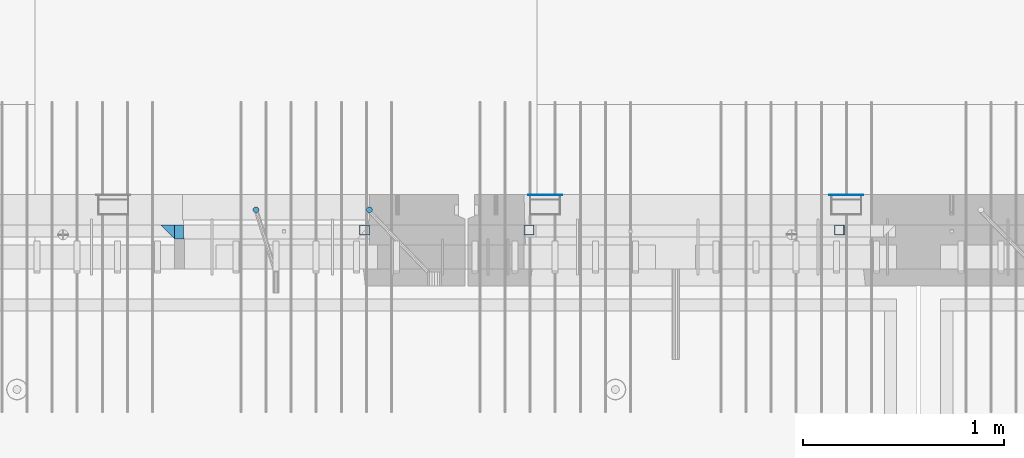
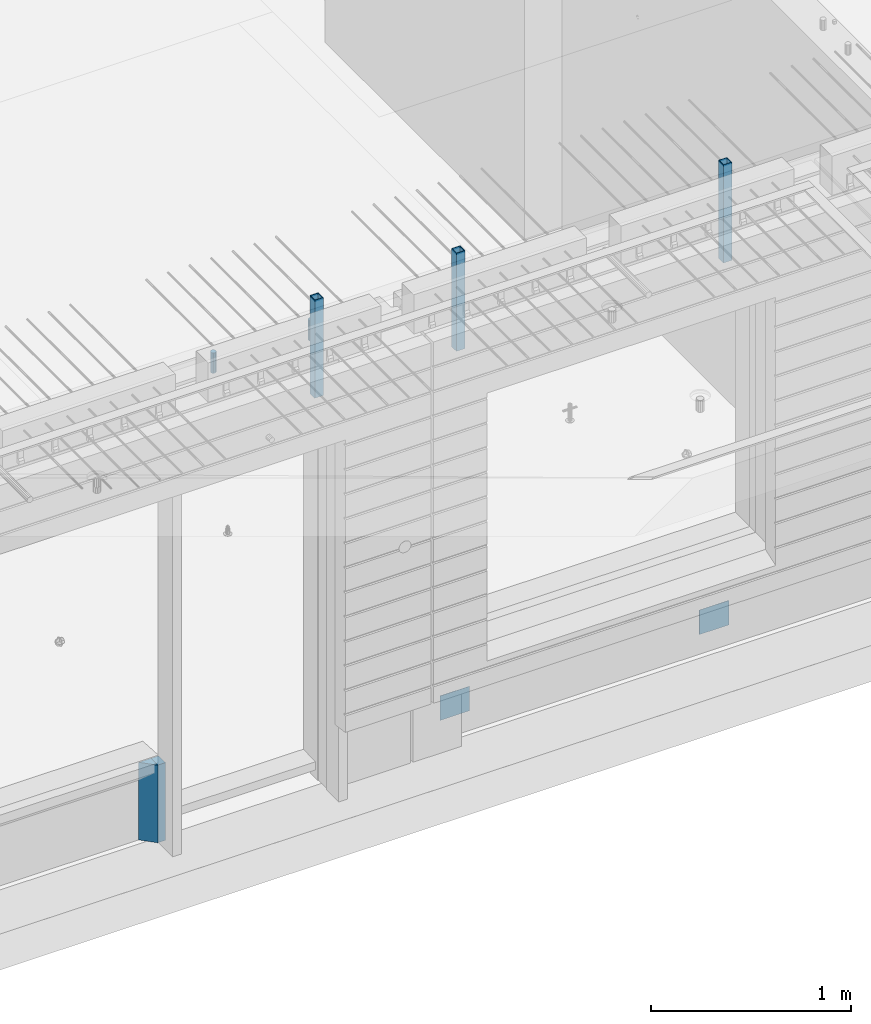
# One storey, part 15 of 325: 9 columns, 7 elements without a shape of their own.
"""IFC2X3 building model written with IfcOpenShell, lengths in millimetres."""

from ifc_helpers import new_model, si_unit, frame, origin_with_axes, place, context, subcontext, project, spatial, faceted_brep, material, type_object, element, aggregate, save


model = new_model("IFC2X3")

# Units and contexts
model_context = context("Model", 3, precision=1e-05, world=origin_with_axes())
body_context = subcontext(model_context, "Body", "Model", "MODEL_VIEW")
ifc_project = project(units=[si_unit("LENGTHUNIT", "METRE", prefix="MILLI"), si_unit("AREAUNIT", "SQUARE_METRE"), si_unit("VOLUMEUNIT", "CUBIC_METRE"), si_unit("MASSUNIT", "GRAM", prefix="KILO"), si_unit("TIMEUNIT", "SECOND"), si_unit("PLANEANGLEUNIT", "RADIAN"), si_unit("SOLIDANGLEUNIT", "STERADIAN"), si_unit("THERMODYNAMICTEMPERATUREUNIT", "DEGREE_CELSIUS"), si_unit("LUMINOUSINTENSITYUNIT", "LUMEN")], contexts=[model_context])

# Site, building, storey
site_placement = place(None, origin_with_axes())
site = spatial("IfcSite", under=ifc_project, at=site_placement, CompositionType="ELEMENT")
building_placement = place(site_placement, origin_with_axes())
building = spatial("IfcBuilding", under=site, at=building_placement, CompositionType="ELEMENT")
storey_placement = place(building_placement, origin_with_axes())
storey = spatial("IfcBuildingStorey", under=building, at=storey_placement, Name="1", CompositionType="ELEMENT", Elevation=0.0)

# Assembly, columns
assembly_1_placement = place(storey_placement, origin_with_axes())
assembly_1 = element("IfcElementAssembly", 1, at=assembly_1_placement, inside=storey, AssemblyPlace="NOTDEFINED", PredefinedType="REINFORCEMENT_UNIT")
ifc_material_1 = material(Name="CONCRETE/C35/45")
column_type_1 = type_object("IfcColumnType", PredefinedType="NOTDEFINED")
column_1_placement = place(assembly_1_placement, frame((24069.9998642727, 7815.0, 81755.0), z_axis=(1.0, 0.0, 0.0), x_axis=(0.0, 0.0, 1.0)))
column_1 = element("IfcColumn", 2, at=column_1_placement, type_object=column_type_1, material=ifc_material_1, Name="SK", context=body_context, shape_type="Brep", body=[
    faceted_brep([(0.0, -35.0, 35.0), (0.0, 35.0, 35.0), (0.0, -35.0, -35.0), (475.0, -35.0, 35.0), (475.0, -35.0, -35.0), (475.0, 35.0, 35.0)], [[[0, 1, 2]], [[3, 0, 2, 4]], [[3, 4, 5]], [[2, 1, 5, 4]], [[0, 3, 5, 1]]]),
])
ifc_material_2 = material(Name="CONCRETE/C40/50")
column_type_2 = type_object("IfcColumnType", PredefinedType="NOTDEFINED")
column_2_placement = place(assembly_1_placement, frame((24129.9998642727, 7815.0, 81755.0), z_axis=(1.0, 0.0, 0.0), x_axis=(0.0, 0.0, 1.0)))
column_2 = element("IfcColumn", 3, at=column_2_placement, type_object=column_type_2, material=ifc_material_2, Name="SK", context=body_context, shape_type="Brep", body=[
    faceted_brep([(0.0, -35.0, -25.0), (0.0, 35.0, -25.0), (475.0, 35.0, -25.0), (475.0, -35.0, -25.0), (0.0, -35.0, 18.8457723764259), (0.0, 35.0, 20.640644171297), (475.0, 35.0, 20.640644171297), (475.0, -35.0, 18.8457723764259)], [[[0, 1, 2, 3]], [[1, 0, 4, 5]], [[2, 1, 5, 6]], [[3, 2, 6, 7]], [[0, 3, 7, 4]], [[6, 5, 4, 7]]]),
])
ifc_material_3 = material()
column_type_3 = type_object("IfcColumnType", Name="D30", PredefinedType="NOTDEFINED")
column_3_placement = place(assembly_1_placement, frame((24510.0000000048, 7924.99999999072, 84407.5), z_axis=(0.0, 1.0, 0.0), x_axis=(0.0, 0.0, 1.0)))
column_3 = element("IfcColumn", 4, at=column_3_placement, type_object=column_type_3, material=ifc_material_3, ObjectType="D30", context=body_context, shape_type="Brep", body=[
    faceted_brep([(0.0, -15.0, 0.0), (0.0, -12.9903810567666, -7.5), (125.0, -12.9903810567666, -7.5), (125.0, -15.0, 0.0), (0.0, -7.5, -12.9903810567666), (125.0, -7.5, -12.9903810567666), (0.0, 0.0, -15.0), (125.0, 0.0, -15.0), (0.0, 7.5, -12.9903810567666), (125.0, 7.5, -12.9903810567666), (0.0, 12.9903810567666, -7.5), (125.0, 12.9903810567666, -7.5), (0.0, 15.0, 0.0), (125.0, 15.0, 0.0), (0.0, 12.9903810567666, 7.5), (125.0, 12.9903810567666, 7.5), (0.0, 7.5, 12.9903810567666), (125.0, 7.5, 12.9903810567666), (0.0, 0.0, 15.0), (125.0, 0.0, 15.0), (0.0, -7.5, 12.9903810567666), (125.0, -7.5, 12.9903810567666), (0.0, -12.9903810567666, 7.5), (125.0, -12.9903810567666, 7.5)], [[[0, 1, 2, 3]], [[1, 4, 5, 2]], [[4, 6, 7, 5]], [[6, 8, 9, 7]], [[8, 10, 11, 9]], [[10, 12, 13, 11]], [[12, 14, 15, 13]], [[14, 16, 17, 15]], [[16, 18, 19, 17]], [[18, 20, 21, 19]], [[20, 22, 23, 21]], [[22, 0, 3, 23]], [[5, 7, 9, 11, 13, 15, 17, 19, 21, 23, 3, 2]], [[22, 20, 18, 16, 14, 12, 10, 8, 6, 4, 1, 0]]]),
])
column_4_placement = place(assembly_1_placement, frame((25074.9926665377, 7925.00000000707, 84407.5), z_axis=(0.0, 1.0, 0.0), x_axis=(0.0, 0.0, 1.0)))
column_4 = element("IfcColumn", 5, at=column_4_placement, type_object=column_type_3, material=ifc_material_3, ObjectType="D30", context=body_context, shape_type="Brep", body=[
    faceted_brep([(0.0, -15.0, 0.0), (0.0, -12.9903810567666, -7.5), (125.0, -12.9903810567666, -7.5), (125.0, -15.0, 0.0), (0.0, -7.5, -12.9903810567666), (125.0, -7.5, -12.9903810567666), (0.0, 0.0, -15.0), (125.0, 0.0, -15.0), (0.0, 7.5, -12.9903810567666), (125.0, 7.5, -12.9903810567666), (0.0, 12.9903810567666, -7.5), (125.0, 12.9903810567666, -7.5), (0.0, 15.0, 0.0), (125.0, 15.0, 0.0), (0.0, 12.9903810567666, 7.5), (125.0, 12.9903810567666, 7.5), (0.0, 7.5, 12.9903810567666), (125.0, 7.5, 12.9903810567666), (0.0, 0.0, 15.0), (125.0, 0.0, 15.0), (0.0, -7.5, 12.9903810567666), (125.0, -7.5, 12.9903810567666), (0.0, -12.9903810567666, 7.5), (125.0, -12.9903810567666, 7.5)], [[[0, 1, 2, 3]], [[1, 4, 5, 2]], [[4, 6, 7, 5]], [[6, 8, 9, 7]], [[8, 10, 11, 9]], [[10, 12, 13, 11]], [[12, 14, 15, 13]], [[14, 16, 17, 15]], [[16, 18, 19, 17]], [[18, 20, 21, 19]], [[20, 22, 23, 21]], [[22, 0, 3, 23]], [[5, 7, 9, 11, 13, 15, 17, 19, 21, 23, 3, 2]], [[22, 20, 18, 16, 14, 12, 10, 8, 6, 4, 1, 0]]]),
])

# Assemblies, columns
assembly_2_placement = place(storey_placement, origin_with_axes())
assembly_2 = element("IfcElementAssembly", 6, at=assembly_2_placement, inside=storey, AssemblyPlace="NOTDEFINED", PredefinedType="REINFORCEMENT_UNIT")
assembly_3_placement = place(assembly_2_placement, origin_with_axes())
assembly_3 = element("IfcElementAssembly", 7, at=assembly_3_placement, Name="Steel Assembly", AssemblyPlace="NOTDEFINED", PredefinedType="NOTDEFINED")
ifc_material_4 = material(Name="Undefined")
column_type_4 = type_object("IfcColumnType", PredefinedType="NOTDEFINED")
column_5_placement = place(assembly_3_placement, frame((25950.0, 7998.99999999844, 81754.9999999985), z_axis=(0.0, 1.0, 0.0), x_axis=(0.0, 0.0, 1.0)))
column_5 = element("IfcColumn", 8, at=column_5_placement, type_object=column_type_4, material=ifc_material_4, Name="SPK2", context=body_context, shape_type="Brep", body=[
    faceted_brep([(0.0, 85.0, -1.0), (0.0, 85.0, 1.0), (150.0, 85.0, 1.0), (150.0, 85.0, -1.0), (0.0, -85.0, 1.0), (150.0, -85.0, 1.0), (0.0, -85.0, -1.0), (150.0, -85.0, -1.0)], [[[0, 1, 2, 3]], [[1, 4, 5, 2]], [[4, 6, 7, 5]], [[6, 0, 3, 7]], [[5, 7, 3, 2]], [[6, 4, 1, 0]]]),
])
aggregate(assembly_3, [column_5])
assembly_4_placement = place(assembly_2_placement, origin_with_axes())
assembly_4 = element("IfcElementAssembly", 9, at=assembly_4_placement, Name="Steel Assembly", AssemblyPlace="NOTDEFINED", PredefinedType="NOTDEFINED")
column_6_placement = place(assembly_4_placement, frame((27450.0, 7998.99999999844, 81754.9999999985), z_axis=(0.0, 1.0, 0.0), x_axis=(0.0, 0.0, 1.0)))
column_6 = element("IfcColumn", 10, at=column_6_placement, type_object=column_type_4, material=ifc_material_4, Name="SPK2", context=body_context, shape_type="Brep", body=[
    faceted_brep([(0.0, 85.0, -1.0), (0.0, 85.0, 1.0), (150.0, 85.0, 1.0), (150.0, 85.0, -1.0), (0.0, -85.0, 1.0), (150.0, -85.0, 1.0), (0.0, -85.0, -1.0), (150.0, -85.0, -1.0)], [[[0, 1, 2, 3]], [[1, 4, 5, 2]], [[4, 6, 7, 5]], [[6, 0, 3, 7]], [[5, 7, 3, 2]], [[6, 4, 1, 0]]]),
])
aggregate(assembly_4, [column_6])
assembly_5_placement = place(assembly_2_placement, origin_with_axes())
assembly_5 = element("IfcElementAssembly", 11, at=assembly_5_placement, Name="Steel Assembly", AssemblyPlace="NOTDEFINED", PredefinedType="RIGID_FRAME")
ifc_material_5 = material(Name="STEEL/S355J2")
column_type_5 = type_object("IfcColumnType", Name="50X50X3", PredefinedType="NOTDEFINED")
column_7_placement = place(assembly_5_placement, frame((25870.0, 7825.0, 84140.0), z_axis=(-1.0, 3.00000001838171e-08, 0.0), x_axis=(0.0, 0.0, 1.0)))
column_7 = element("IfcColumn", 12, at=column_7_placement, type_object=column_type_5, material=ifc_material_5, ObjectType="50X50X3", context=body_context, shape_type="Brep", body=[
    faceted_brep([(0.0, 22.0, -22.0), (0.0, -22.0, -22.0), (600.0, -22.0, -22.0), (600.0, 22.0, -22.0), (0.0, -22.0, 22.0), (600.0, -22.0, 22.0), (0.0, 22.0, 22.0), (600.0, 22.0, 22.0), (0.0, 25.0, -25.0), (0.0, 25.0, 25.0), (600.0, 25.0, 25.0), (600.0, 25.0, -25.0), (0.0, -25.0, 25.0), (600.0, -25.0, 25.0), (0.0, -25.0, -25.0), (600.0, -25.0, -25.0)], [[[0, 1, 2, 3]], [[1, 4, 5, 2]], [[4, 6, 7, 5]], [[6, 0, 3, 7]], [[8, 9, 10, 11]], [[9, 12, 13, 10]], [[12, 14, 15, 13]], [[14, 8, 11, 15]], [[13, 15, 11, 10], [5, 7, 3, 2]], [[14, 12, 9, 8], [6, 4, 1, 0]]]),
])
aggregate(assembly_5, [column_7])

# Assembly
assembly_6_placement = place(assembly_1_placement, origin_with_axes())
assembly_6 = element("IfcElementAssembly", 13, at=assembly_6_placement, Name="Steel Assembly", AssemblyPlace="NOTDEFINED", PredefinedType="RIGID_FRAME")

aggregate(assembly_1, [column_3, column_4, assembly_6, column_1, column_2])

# Column
column_8_placement = place(assembly_6_placement, frame((25050.0, 7825.0, 84140.0), z_axis=(-1.0, 3.00000001838171e-08, 0.0), x_axis=(0.0, 0.0, 1.0)))
column_8 = element("IfcColumn", 14, at=column_8_placement, type_object=column_type_5, material=ifc_material_5, ObjectType="50X50X3", context=body_context, shape_type="Brep", body=[
    faceted_brep([(0.0, 22.0, -22.0), (0.0, -22.0, -22.0), (600.0, -22.0, -22.0), (600.0, 22.0, -22.0), (0.0, -22.0, 22.0), (600.0, -22.0, 22.0), (0.0, 22.0, 22.0), (600.0, 22.0, 22.0), (0.0, 25.0, -25.0), (0.0, 25.0, 25.0), (600.0, 25.0, 25.0), (600.0, 25.0, -25.0), (0.0, -25.0, 25.0), (600.0, -25.0, 25.0), (0.0, -25.0, -25.0), (600.0, -25.0, -25.0)], [[[0, 1, 2, 3]], [[1, 4, 5, 2]], [[4, 6, 7, 5]], [[6, 0, 3, 7]], [[8, 9, 10, 11]], [[9, 12, 13, 10]], [[12, 14, 15, 13]], [[14, 8, 11, 15]], [[13, 15, 11, 10], [5, 7, 3, 2]], [[14, 12, 9, 8], [6, 4, 1, 0]]]),
])

aggregate(assembly_6, [column_8])

# Assembly
assembly_7_placement = place(assembly_2_placement, origin_with_axes())
assembly_7 = element("IfcElementAssembly", 15, at=assembly_7_placement, Name="Steel Assembly", AssemblyPlace="NOTDEFINED", PredefinedType="RIGID_FRAME")

aggregate(assembly_2, [assembly_5, assembly_3, assembly_4, assembly_7])

# Column
column_9_placement = place(assembly_7_placement, frame((27415.0, 7825.0, 84140.0), z_axis=(-1.0, 3.00000001838171e-08, 0.0), x_axis=(0.0, 0.0, 1.0)))
column_9 = element("IfcColumn", 16, at=column_9_placement, type_object=column_type_5, material=ifc_material_5, ObjectType="50X50X3", context=body_context, shape_type="Brep", body=[
    faceted_brep([(0.0, 22.0, -22.0), (0.0, -22.0, -22.0), (600.0, -22.0, -22.0), (600.0, 22.0, -22.0), (0.0, -22.0, 22.0), (600.0, -22.0, 22.0), (0.0, 22.0, 22.0), (600.0, 22.0, 22.0), (0.0, 25.0, -25.0), (0.0, 25.0, 25.0), (600.0, 25.0, 25.0), (600.0, 25.0, -25.0), (0.0, -25.0, 25.0), (600.0, -25.0, 25.0), (0.0, -25.0, -25.0), (600.0, -25.0, -25.0)], [[[0, 1, 2, 3]], [[1, 4, 5, 2]], [[4, 6, 7, 5]], [[6, 0, 3, 7]], [[8, 9, 10, 11]], [[9, 12, 13, 10]], [[12, 14, 15, 13]], [[14, 8, 11, 15]], [[13, 15, 11, 10], [5, 7, 3, 2]], [[14, 12, 9, 8], [6, 4, 1, 0]]]),
])

aggregate(assembly_7, [column_9])

save(model, "model.ifc")
